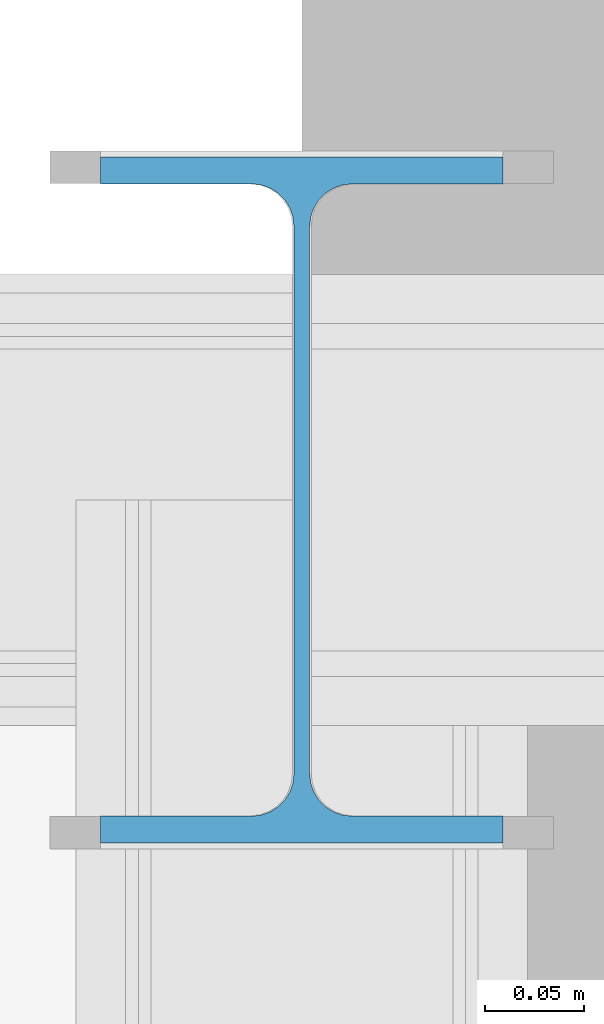
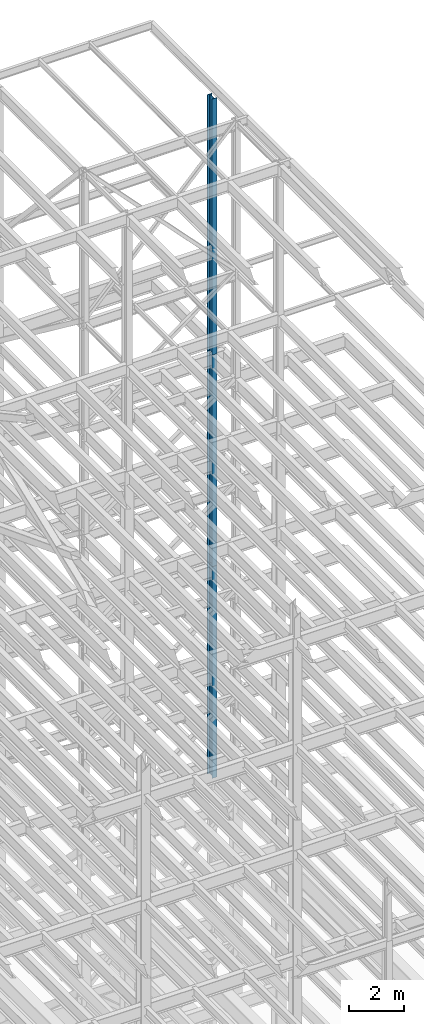
# One storey, part 120 of 150: 3 columns.
"""IFC2X3 building model written with IfcOpenShell, lengths in millimetres."""

from ifc_helpers import new_model, si_unit, frame, origin_with_axes, origin_2d_with_axis, place, context, subcontext, project, spatial, i_section, extrude, material, type_object, element, save


model = new_model("IFC2X3")

# Units and contexts
model_context = context("Model", 3, precision=1e-05, world=origin_with_axes())
body_context = subcontext(model_context, "Body", "Model", "MODEL_VIEW")
ifc_project = project(units=[si_unit("LENGTHUNIT", "METRE", prefix="MILLI"), si_unit("AREAUNIT", "SQUARE_METRE"), si_unit("VOLUMEUNIT", "CUBIC_METRE"), si_unit("MASSUNIT", "GRAM", prefix="KILO"), si_unit("TIMEUNIT", "SECOND"), si_unit("PLANEANGLEUNIT", "RADIAN"), si_unit("SOLIDANGLEUNIT", "STERADIAN"), si_unit("THERMODYNAMICTEMPERATUREUNIT", "DEGREE_CELSIUS"), si_unit("LUMINOUSINTENSITYUNIT", "LUMEN")], contexts=[model_context])

# Site, building, storey
site_placement = place(None, origin_with_axes())
site = spatial("IfcSite", under=ifc_project, at=site_placement, CompositionType="ELEMENT")
building_placement = place(site_placement, origin_with_axes())
building = spatial("IfcBuilding", under=site, at=building_placement, Name="Undefined", CompositionType="ELEMENT")
storey_placement = place(building_placement, origin_with_axes())
storey = spatial("IfcBuildingStorey", under=building, at=storey_placement, Name="Undefined", CompositionType="ELEMENT", Elevation=0.0)

# Columns
ifc_material = material(Name="STEEL/A992")
column_type = type_object("IfcColumnType", Name="W14X43", PredefinedType="NOTDEFINED")
column_1_placement = place(storey_placement, frame((88595.2, 27355.8, 54483.0), z_axis=(0.0, 0.0, 1.0), x_axis=(1.0, 0.0, 0.0)))
element("IfcColumn", 1, at=column_1_placement, inside=storey, type_object=column_type, material=ifc_material, Name="COLUMN", ObjectType="W14X43", context=body_context, shape_type="SweptSolid", body=[
    extrude(i_section(OverallWidth=203.2, OverallDepth=346.075, WebThickness=7.9375, FlangeThickness=13.462, FilletRadius=21.4629, at=origin_2d_with_axis()), frame((0.0, 0.0, 11430.0), z_axis=(0.0, 0.0, -1.0), x_axis=(-1.0, 0.0, 0.0)), (0.0, 0.0, 1.0), 11430.0),
])
column_2_placement = place(storey_placement, frame((88595.2, 27355.8, 45034.2), z_axis=(0.0, 0.0, 1.0), x_axis=(1.0, 0.0, 0.0)))
element("IfcColumn", 2, at=column_2_placement, inside=storey, type_object=column_type, material=ifc_material, Name="COLUMN", ObjectType="W14X43", context=body_context, shape_type="SweptSolid", body=[
    extrude(i_section(OverallWidth=203.2, OverallDepth=346.075, WebThickness=7.9375, FlangeThickness=13.462, FilletRadius=21.4629, at=origin_2d_with_axis()), frame((0.0, 0.0, 9448.8), z_axis=(0.0, 0.0, -1.0), x_axis=(-1.0, 0.0, 0.0)), (0.0, 0.0, 1.0), 9448.8),
])
column_3_placement = place(storey_placement, frame((88595.2, 27355.8, 35585.4), z_axis=(0.0, 0.0, 1.0), x_axis=(1.0, 0.0, 0.0)))
element("IfcColumn", 3, at=column_3_placement, inside=storey, type_object=column_type, material=ifc_material, Name="COLUMN", ObjectType="W14X43", context=body_context, shape_type="SweptSolid", body=[
    extrude(i_section(OverallWidth=203.2, OverallDepth=346.075, WebThickness=7.9375, FlangeThickness=13.462, FilletRadius=21.4629, at=origin_2d_with_axis()), frame((0.0, 0.0, 9448.8), z_axis=(0.0, 0.0, -1.0), x_axis=(-1.0, 0.0, 0.0)), (0.0, 0.0, 1.0), 9448.79999999999),
])

save(model, "model.ifc")
